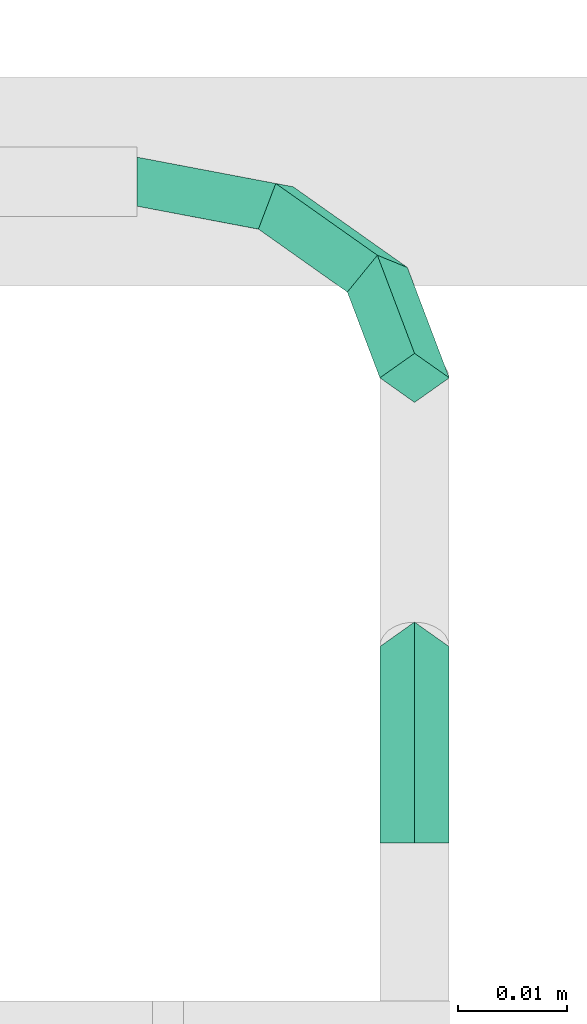
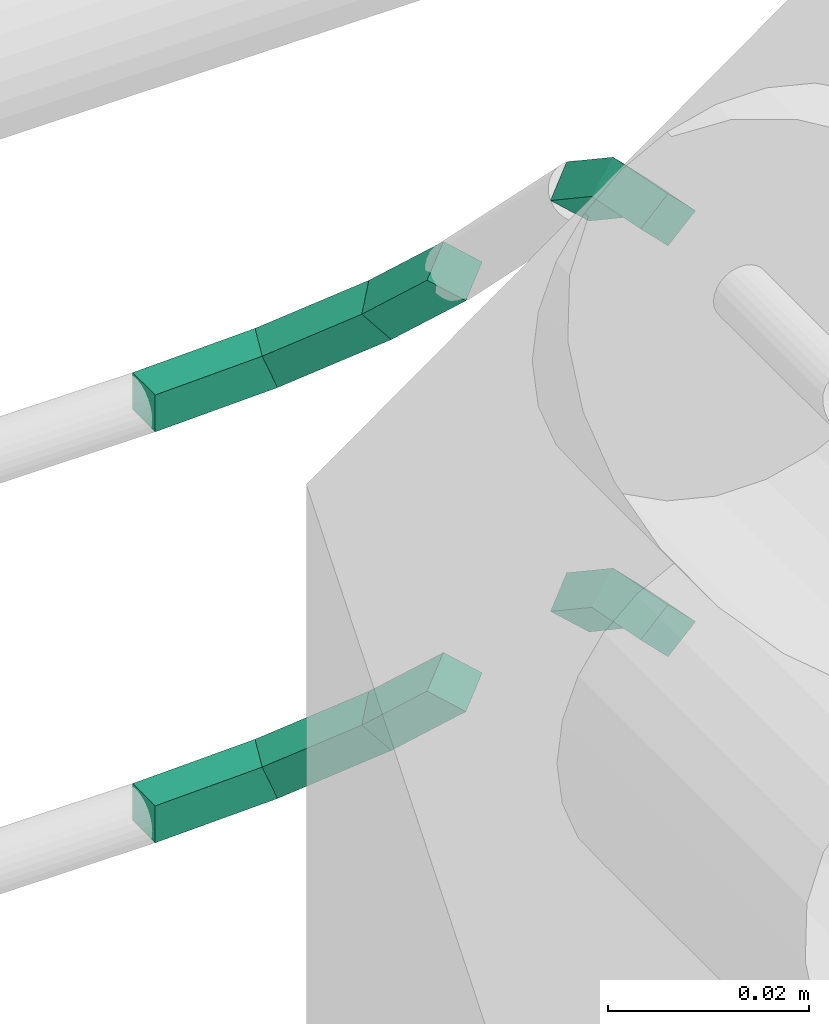
# One storey, part 43 of 45: 4 flow fittings.
"""IFC2X3 building model written with IfcOpenShell, lengths in millimetres."""

from ifc_helpers import new_model, entity, si_unit, converted_unit, derived_unit, direction, frame, origin, place, context, subcontext, project, spatial, faceted_brep, material, type_object, element, save


model = new_model("IFC2X3")

# Units and contexts
model_context = context("Model", 3, precision=0.01, world=origin(), true_north=direction((6.12303176911189e-17, 1.0)))
body_context = subcontext(model_context, "Body", "Model", "MODEL_VIEW")
ifc_project = project(units=[si_unit("LENGTHUNIT", "METRE", prefix="MILLI"), si_unit("AREAUNIT", "SQUARE_METRE"), si_unit("VOLUMEUNIT", "CUBIC_METRE"), converted_unit("PLANEANGLEUNIT", "DEGREE", entity("IfcRatioMeasure", 0.0174532925199433), si_unit("PLANEANGLEUNIT", "RADIAN"), dimensions=[0, 0, 0, 0, 0, 0, 0]), si_unit("MASSUNIT", "GRAM", prefix="KILO"), derived_unit("MASSDENSITYUNIT", [(si_unit("MASSUNIT", "GRAM", prefix="KILO"), 1), (si_unit("LENGTHUNIT", "METRE"), -3)]), derived_unit("MOMENTOFINERTIAUNIT", [(si_unit("LENGTHUNIT", "METRE"), 4)]), si_unit("TIMEUNIT", "SECOND"), si_unit("FREQUENCYUNIT", "HERTZ"), si_unit("THERMODYNAMICTEMPERATUREUNIT", "DEGREE_CELSIUS"), derived_unit("THERMALTRANSMITTANCEUNIT", [(si_unit("MASSUNIT", "GRAM", prefix="KILO"), 1), (si_unit("THERMODYNAMICTEMPERATUREUNIT", "KELVIN"), -1), (si_unit("TIMEUNIT", "SECOND"), -3)]), derived_unit("VOLUMETRICFLOWRATEUNIT", [(si_unit("LENGTHUNIT", "METRE"), 3), (si_unit("TIMEUNIT", "SECOND"), -1)]), derived_unit("MASSFLOWRATEUNIT", [(si_unit("MASSUNIT", "GRAM", prefix="KILO"), 1), (si_unit("TIMEUNIT", "SECOND"), -1)]), derived_unit("ROTATIONALFREQUENCYUNIT", [(si_unit("TIMEUNIT", "SECOND"), -1)]), si_unit("ELECTRICCURRENTUNIT", "AMPERE"), si_unit("ELECTRICVOLTAGEUNIT", "VOLT"), si_unit("POWERUNIT", "WATT"), si_unit("FORCEUNIT", "NEWTON", prefix="KILO"), si_unit("ILLUMINANCEUNIT", "LUX"), si_unit("LUMINOUSFLUXUNIT", "LUMEN"), si_unit("LUMINOUSINTENSITYUNIT", "CANDELA"), derived_unit("USERDEFINED", [(si_unit("MASSUNIT", "GRAM", prefix="KILO"), -1), (si_unit("LENGTHUNIT", "METRE"), -2), (si_unit("TIMEUNIT", "SECOND"), 3), (si_unit("LUMINOUSFLUXUNIT", "LUMEN"), 1)]), derived_unit("LINEARVELOCITYUNIT", [(si_unit("LENGTHUNIT", "METRE"), 1), (si_unit("TIMEUNIT", "SECOND"), -1)]), si_unit("PRESSUREUNIT", "PASCAL"), derived_unit("USERDEFINED", [(si_unit("LENGTHUNIT", "METRE"), -2), (si_unit("MASSUNIT", "GRAM", prefix="KILO"), 1), (si_unit("TIMEUNIT", "SECOND"), -2)]), derived_unit("LINEARFORCEUNIT", [(si_unit("MASSUNIT", "GRAM", prefix="KILO"), 1), (si_unit("LENGTHUNIT", "METRE"), 1), (si_unit("TIMEUNIT", "SECOND"), -2), (si_unit("LENGTHUNIT", "METRE"), -1)]), derived_unit("PLANARFORCEUNIT", [(si_unit("MASSUNIT", "GRAM", prefix="KILO"), 1), (si_unit("LENGTHUNIT", "METRE"), 1), (si_unit("TIMEUNIT", "SECOND"), -2), (si_unit("LENGTHUNIT", "METRE"), -2)])], contexts=[model_context])

# Site, building, storey
site_placement = place(None, frame((-24836.06, 8968.75, 0.0)))
site = spatial("IfcSite", under=ifc_project, at=site_placement, CompositionType="ELEMENT")
building_placement = place(site_placement, origin())
building = spatial("IfcBuilding", under=site, at=building_placement, CompositionType="ELEMENT")
storey_placement = place(building_placement, frame((0.0, 0.0, -4200.0)))
storey = spatial("IfcBuildingStorey", under=building, at=storey_placement, CompositionType="ELEMENT", Elevation=-4200.0)

# Flow fittings
ifc_material = material()
pipe_fitting_type_1 = type_object("IfcPipeFittingType", PredefinedType="NOTDEFINED", material=ifc_material)
for number, where in (
    (1, (87770.85, -983.96, 2147.75)),
    (2, (87770.85, -983.96, 2097.75)),
):
    element("IfcFlowFitting", number, at=place(storey_placement, frame(where)), inside=storey, type_object=pipe_fitting_type_1, context=body_context, shape_type="Brep", body=[
        faceted_brep([(28.58, 2.25, 20.21), (24.75, 12.35, 10.1), (22.0, 13.47, 13.47), (25.4, 4.49, 22.45), (19.25, 10.1, 12.35), (22.23, 2.25, 20.21), (22.0, 8.98, 8.98), (25.4, 0.0, 17.96), (14.29, 19.74, 2.71), (12.7, 20.04, 6.9), (11.11, 15.86, 6.6), (12.7, 15.55, 2.41), (0.0, 22.45, 0.0), (0.0, 22.45, 4.49), (0.0, 17.96, 4.49), (0.0, 17.96, 0.0)], [[[0, 1, 2, 3]], [[3, 2, 4, 5]], [[5, 4, 6, 7]], [[7, 6, 1, 0]], [[1, 8, 9, 2]], [[2, 9, 10, 4]], [[4, 10, 11, 6]], [[6, 11, 8, 1]], [[8, 12, 13, 9]], [[9, 13, 14, 10]], [[10, 14, 15, 11]], [[11, 15, 12, 8]], [[7, 0, 3, 5]], [[12, 15, 14, 13]]]),
    ])
pipe_fitting_type_2 = type_object("IfcPipeFittingType", PredefinedType="NOTDEFINED", material=ifc_material)
for number, where in (
    (3, (87793.07, -1024.27, 2190.32)),
    (4, (87793.07, -1024.27, 2140.32)),
):
    element("IfcFlowFitting", number, at=place(storey_placement, frame(where)), inside=storey, type_object=pipe_fitting_type_2, context=body_context, shape_type="Brep", body=[
        faceted_brep([(3.17, 20.21, 4.49), (3.17, 10.94, 10.68), (6.35, 9.72, 7.75), (6.35, 17.96, 2.25), (3.17, 8.51, 4.82), (3.17, 15.72, 0.0), (0.0, 9.72, 7.75), (0.0, 17.96, 2.25), (3.17, 0.0, 12.86), (6.35, 0.0, 9.68), (3.17, 0.0, 6.51), (0.0, 0.0, 9.68)], [[[0, 1, 2, 3]], [[3, 2, 4, 5]], [[5, 4, 6, 7]], [[7, 6, 1, 0]], [[1, 8, 9, 2]], [[2, 9, 10, 4]], [[4, 10, 11, 6]], [[6, 11, 8, 1]], [[7, 0, 3, 5]], [[8, 11, 10, 9]]]),
    ])

save(model, "model.ifc")
